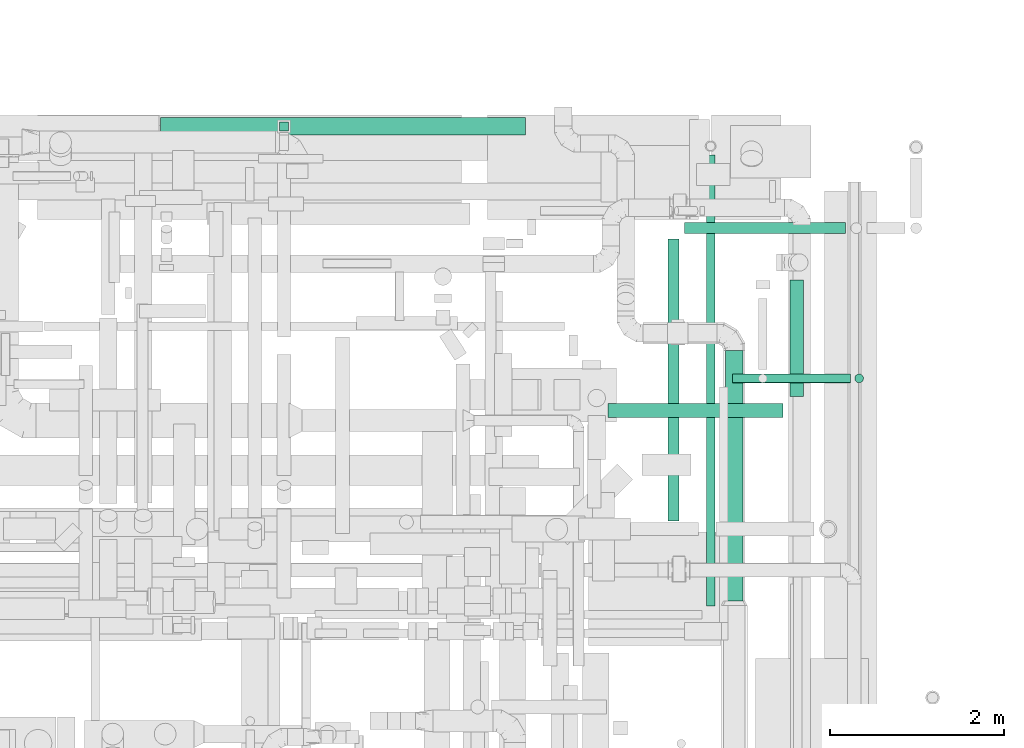
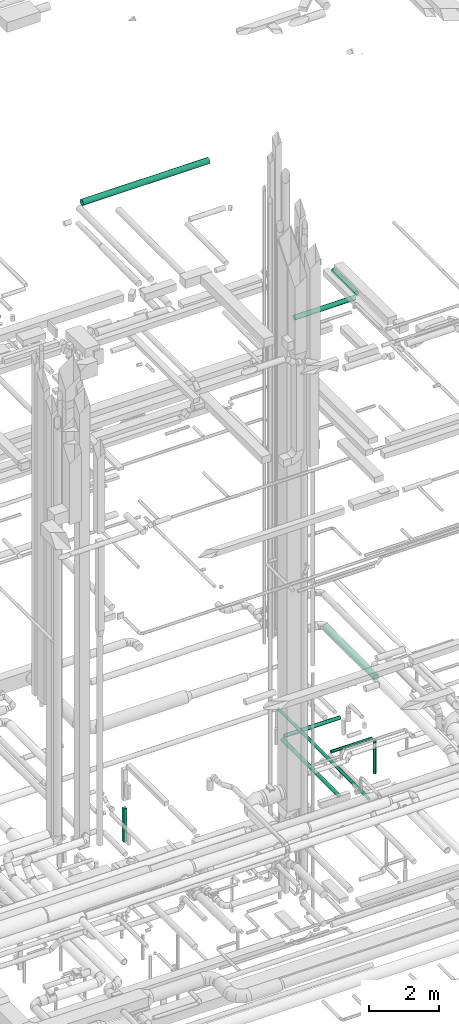
# One storey, part 78 of 337: 10 flow segments.
"""IFC2X3 building model written with IfcOpenShell, lengths in millimetres."""

import ifcopenshell
import ifcopenshell.guid

model = None  # the IFC model being written
_history = None  # IfcOwnerHistory: only IFC2X3 demands one
_inside = {}  # id of a spatial element -> (the spatial element, [elements in it])
_under = {}  # id of a project, library or spatial element -> (it, [spatial elements below it])
_declared = {}  # id of a project -> (the project, [libraries it declares])
_typed = {}  # id of a type object -> (the type object, [elements of that type])
_made_of = {}  # id of a material, layer set ... -> (it, [elements and type objects made of it])


def new_model(schema):
    """Start an empty IFC model of exactly this schema.

    Asked for "IFC4X3", IfcOpenShell would pick the latest addendum, in which some entities
    have other attributes; the version numbers below select the first issue.
    IFC2X3 requires an IfcOwnerHistory on every rooted entity: one is made here for all.
    """
    global model, _history
    if schema == "IFC4X3":
        model = ifcopenshell.file(schema_version=(4, 3, 0, 0))
    else:
        model = ifcopenshell.file(schema=schema)
    _inside.clear()
    _under.clear()
    _declared.clear()
    _typed.clear()
    _made_of.clear()
    _history = None
    if model.schema == "IFC2X3":
        org = make("IfcOrganization", Name="unknown")
        user = make(
            "IfcPersonAndOrganization",
            ThePerson=make("IfcPerson", FamilyName="unknown"),
            TheOrganization=org,
        )
        app = make(
            "IfcApplication",
            ApplicationDeveloper=org,
            Version="unknown",
            ApplicationFullName="unknown",
            ApplicationIdentifier="unknown",
        )
        _history = make(
            "IfcOwnerHistory",
            OwningUser=user,
            OwningApplication=app,
            ChangeAction="ADDED",
            CreationDate=0,
        )
    return model


def make(cls, **values):
    """One entity of the class cls with the attributes given. An attribute that is None is left unset."""
    return model.create_entity(
        cls, **{name: value for name, value in values.items() if value is not None}
    )


def entity(cls, *values):
    """Any entity or typed value of the class cls, its attributes in the order of the schema. None: left unset."""
    e = model.create_entity(cls)
    for i, value in enumerate(values):
        if value is not None:
            e[i] = value
    return e


def rooted(cls, **values):
    """An entity with a GlobalId (a new one), such as an element, a storey or a relation."""
    return make(cls, GlobalId=ifcopenshell.guid.new(), OwnerHistory=_history, **values)


def si_unit(unit_type, name, prefix=None):
    """IfcSIUnit, for example si_unit("LENGTHUNIT", "METRE", prefix="MILLI")."""
    return make("IfcSIUnit", UnitType=unit_type, Prefix=prefix, Name=name)


def converted_unit(unit_type, name, factor, base, dimensions=None, offset=None):
    """IfcConversionBasedUnit, such as the inch: factor (a typed value) times the base unit."""
    return make(
        "IfcConversionBasedUnit"
        if offset is None
        else "IfcConversionBasedUnitWithOffset",
        ConversionOffset=offset,
        Dimensions=None
        if dimensions is None
        else entity("IfcDimensionalExponents", *dimensions),
        UnitType=unit_type,
        Name=name,
        ConversionFactor=make(
            "IfcMeasureWithUnit", ValueComponent=factor, UnitComponent=base
        ),
    )


def derived_unit(unit_type, elements):
    """IfcDerivedUnit: a product of units, each with its exponent."""
    return make(
        "IfcDerivedUnit",
        Elements=[
            make("IfcDerivedUnitElement", Unit=unit, Exponent=power)
            for unit, power in elements
        ],
        UnitType=unit_type,
    )


def assignment(units):
    """IfcUnitAssignment: the units of a project."""
    return None if units is None else make("IfcUnitAssignment", Units=units)


def point(xyz):
    """IfcCartesianPoint."""
    return None if xyz is None else make("IfcCartesianPoint", Coordinates=xyz)


def direction(xyz):
    """IfcDirection."""
    return None if xyz is None else make("IfcDirection", DirectionRatios=xyz)


def frame(location, z_axis=None, x_axis=None):
    """IfcAxis2Placement3D, a coordinate frame: its origin and axes. An axis left out is left unset."""
    return make(
        "IfcAxis2Placement3D",
        Location=point(location),
        Axis=direction(z_axis),
        RefDirection=direction(x_axis),
    )


def frame_2d(location, x_axis=None):
    """IfcAxis2Placement2D, a coordinate frame in the plane: its origin and x axis."""
    return make(
        "IfcAxis2Placement2D", Location=point(location), RefDirection=direction(x_axis)
    )


def origin():
    """The frame at (0, 0, 0) with its axes left unset."""
    return frame((0.0, 0.0, 0.0))


def origin_2d_with_axis():
    """The frame at (0, 0) in the plane with the x axis (1, 0) written out."""
    return frame_2d((0.0, 0.0), x_axis=(1.0, 0.0))


def place(relative_to, where):
    """IfcLocalPlacement: puts the frame where relative to a parent placement (None: the world)."""
    return make(
        "IfcLocalPlacement", PlacementRelTo=relative_to, RelativePlacement=where
    )


def context(
    kind, dimensions, precision=None, world=None, true_north=None, identifier=None
):
    """IfcGeometricRepresentationContext, for example the 3D "Model" context."""
    return make(
        "IfcGeometricRepresentationContext",
        ContextIdentifier=identifier,
        ContextType=kind,
        CoordinateSpaceDimension=dimensions,
        Precision=precision,
        WorldCoordinateSystem=world,
        TrueNorth=true_north,
    )


def subcontext(parent, identifier, kind, view, scale=None):
    """IfcGeometricRepresentationSubContext, for example "Body" below "Model"."""
    return make(
        "IfcGeometricRepresentationSubContext",
        ContextIdentifier=identifier,
        ContextType=kind,
        ParentContext=parent,
        TargetScale=scale,
        TargetView=view,
    )


def project(units=None, contexts=None):
    """IfcProject with its units and contexts."""
    return rooted(
        "IfcProject",
        Name="project",
        RepresentationContexts=contexts,
        UnitsInContext=assignment(units),
    )


def spatial(cls, under=None, at=None, **own):
    """A site, building, storey or space (cls), placed at a placement, below another one or the project."""
    s = rooted(cls, ObjectPlacement=at, **own)
    if under is not None:
        _under.setdefault(under.id(), (under, []))[1].append(s)
    return s


def profile(cls, at=None, kind="AREA", **sizes):
    """A parametric profile (cls). Its sizes go by their IFC names, for example OverallWidth=200.0."""
    return make(cls, ProfileType=kind, Position=at, **sizes)


def rectangle(**sizes):
    """IfcRectangleProfileDef."""
    return profile("IfcRectangleProfileDef", **sizes)


def circle(**sizes):
    """IfcCircleProfileDef."""
    return profile("IfcCircleProfileDef", **sizes)


def extrude(swept, where, along, depth):
    """IfcExtrudedAreaSolid: the profile swept, set in the frame where, extruded along a direction by depth."""
    return make(
        "IfcExtrudedAreaSolid",
        SweptArea=swept,
        Position=where,
        ExtrudedDirection=direction(along),
        Depth=depth,
    )


def shape(context_of_items, identifier, shape_type, items):
    """IfcShapeRepresentation: the items that make up one representation, for example the "Body"."""
    return make(
        "IfcShapeRepresentation",
        ContextOfItems=context_of_items,
        RepresentationIdentifier=identifier,
        RepresentationType=shape_type,
        Items=items,
    )


def made_of(thing, what):
    """Note that an element or type object is made of a material, layer set ...; save() writes the relation."""
    if what is not None:
        _made_of.setdefault(what.id(), (what, []))[1].append(thing)
    return thing


def type_object(cls, material=None, **own):
    """A type object (cls), such as IfcWallType, which elements share."""
    return made_of(rooted(cls, **own), material)


def element(
    cls,
    number,
    at=None,
    inside=None,
    cuts=None,
    type_object=None,
    material=None,
    context=None,
    identifier="Body",
    shape_type=None,
    held_by="IfcProductDefinitionShape",
    body=None,
    shapes=None,
    **own,
):
    """One element of the class cls, such as IfcWall. Its Tag is "e" and its number.

    at: its placement. inside: the storey or other place that contains it. cuts: it is an
    opening in that element (IfcRelVoidsElement). A single representation is given by context,
    identifier, shape_type and body (its items); several are given by shapes. held_by: the class
    of the entity that holds the representations. save() writes the other relations.
    """
    e = rooted(cls, Tag="e%d" % number, ObjectPlacement=at, **own)
    if body is not None:
        shapes = [shape(context, identifier, shape_type, body)]
    if shapes is not None:
        e.Representation = make(held_by, Representations=shapes)
    if inside is not None:
        _inside.setdefault(inside.id(), (inside, []))[1].append(e)
    if cuts is not None:
        rooted(
            "IfcRelVoidsElement", RelatingBuildingElement=cuts, RelatedOpeningElement=e
        )
    if type_object is not None:
        _typed.setdefault(type_object.id(), (type_object, []))[1].append(e)
    return made_of(e, material)


def aggregate(whole, parts):
    """IfcRelAggregates: a whole, such as a stair, and the parts it consists of."""
    return rooted("IfcRelAggregates", RelatingObject=whole, RelatedObjects=parts)


def save(model, path):
    """Write the relations noted so far, then the file.

    IfcRelAggregates (storeys below a building ...), IfcRelContainedInSpatialStructure (elements
    in a storey), IfcRelDefinesByType, IfcRelAssociatesMaterial and IfcRelDeclares: one each for
    every whole, place, type object, material and project.
    """
    for whole, parts in _under.values():
        aggregate(whole, parts)
    for where, things in _inside.values():
        rooted(
            "IfcRelContainedInSpatialStructure",
            RelatedElements=things,
            RelatingStructure=where,
        )
    for kind, things in _typed.values():
        rooted("IfcRelDefinesByType", RelatedObjects=things, RelatingType=kind)
    for what, things in _made_of.values():
        rooted("IfcRelAssociatesMaterial", RelatedObjects=things, RelatingMaterial=what)
    for by, libraries in _declared.values():
        rooted("IfcRelDeclares", RelatingContext=by, RelatedDefinitions=libraries)
    model.write(path)


model = new_model("IFC2X3")

# Units and contexts
model_context = context("Model", 3, precision=0.01, world=origin(), true_north=direction((6.12303176911189e-17, 1.0)))
body_context = subcontext(model_context, "Body", "Model", "MODEL_VIEW")
ifc_project = project(units=[si_unit("LENGTHUNIT", "METRE", prefix="MILLI"), si_unit("AREAUNIT", "SQUARE_METRE"), si_unit("VOLUMEUNIT", "CUBIC_METRE"), converted_unit("PLANEANGLEUNIT", "DEGREE", entity("IfcRatioMeasure", 0.0174532925199433), si_unit("PLANEANGLEUNIT", "RADIAN"), dimensions=[0, 0, 0, 0, 0, 0, 0]), si_unit("MASSUNIT", "GRAM", prefix="KILO"), derived_unit("MASSDENSITYUNIT", [(si_unit("MASSUNIT", "GRAM", prefix="KILO"), 1), (si_unit("LENGTHUNIT", "METRE"), -3)]), derived_unit("MOMENTOFINERTIAUNIT", [(si_unit("LENGTHUNIT", "METRE"), 4)]), si_unit("TIMEUNIT", "SECOND"), si_unit("FREQUENCYUNIT", "HERTZ"), si_unit("THERMODYNAMICTEMPERATUREUNIT", "DEGREE_CELSIUS"), derived_unit("THERMALTRANSMITTANCEUNIT", [(si_unit("MASSUNIT", "GRAM", prefix="KILO"), 1), (si_unit("THERMODYNAMICTEMPERATUREUNIT", "KELVIN"), -1), (si_unit("TIMEUNIT", "SECOND"), -3)]), derived_unit("VOLUMETRICFLOWRATEUNIT", [(si_unit("LENGTHUNIT", "METRE"), 3), (si_unit("TIMEUNIT", "SECOND"), -1)]), derived_unit("MASSFLOWRATEUNIT", [(si_unit("MASSUNIT", "GRAM", prefix="KILO"), 1), (si_unit("TIMEUNIT", "SECOND"), -1)]), derived_unit("ROTATIONALFREQUENCYUNIT", [(si_unit("TIMEUNIT", "SECOND"), -1)]), si_unit("ELECTRICCURRENTUNIT", "AMPERE"), si_unit("ELECTRICVOLTAGEUNIT", "VOLT"), si_unit("POWERUNIT", "WATT"), si_unit("FORCEUNIT", "NEWTON", prefix="KILO"), si_unit("ILLUMINANCEUNIT", "LUX"), si_unit("LUMINOUSFLUXUNIT", "LUMEN"), si_unit("LUMINOUSINTENSITYUNIT", "CANDELA"), derived_unit("USERDEFINED", [(si_unit("MASSUNIT", "GRAM", prefix="KILO"), -1), (si_unit("LENGTHUNIT", "METRE"), -2), (si_unit("TIMEUNIT", "SECOND"), 3), (si_unit("LUMINOUSFLUXUNIT", "LUMEN"), 1)]), derived_unit("LINEARVELOCITYUNIT", [(si_unit("LENGTHUNIT", "METRE"), 1), (si_unit("TIMEUNIT", "SECOND"), -1)]), si_unit("PRESSUREUNIT", "PASCAL"), derived_unit("USERDEFINED", [(si_unit("LENGTHUNIT", "METRE"), -2), (si_unit("MASSUNIT", "GRAM", prefix="KILO"), 1), (si_unit("TIMEUNIT", "SECOND"), -2)]), derived_unit("LINEARFORCEUNIT", [(si_unit("MASSUNIT", "GRAM", prefix="KILO"), 1), (si_unit("LENGTHUNIT", "METRE"), 1), (si_unit("TIMEUNIT", "SECOND"), -2), (si_unit("LENGTHUNIT", "METRE"), -1)]), derived_unit("PLANARFORCEUNIT", [(si_unit("MASSUNIT", "GRAM", prefix="KILO"), 1), (si_unit("LENGTHUNIT", "METRE"), 1), (si_unit("TIMEUNIT", "SECOND"), -2), (si_unit("LENGTHUNIT", "METRE"), -2)])], contexts=[model_context])

# Site, building, storey
site_placement = place(None, origin())
site = spatial("IfcSite", under=ifc_project, at=site_placement, CompositionType="ELEMENT")
building_placement = place(site_placement, origin())
building = spatial("IfcBuilding", under=site, at=building_placement, CompositionType="ELEMENT")
storey_placement = place(building_placement, origin())
storey = spatial("IfcBuildingStorey", under=building, at=storey_placement, CompositionType="ELEMENT", Elevation=0.0)

# Flow segments
duct_segment_type_1 = type_object("IfcDuctSegmentType", PredefinedType="NOTDEFINED")
flow_segment_1_placement = place(storey_placement, frame((58414.14, 19923.87, -3635.0)))
element("IfcFlowSegment", 1, at=flow_segment_1_placement, inside=storey, type_object=duct_segment_type_1, context=body_context, shape_type="SweptSolid", body=[
    extrude(rectangle(XDim=99.9999999999946, YDim=99.9999999999989, at=origin_2d_with_axis()), frame((50.0, 50.0, 0.0)), (0.0, 0.0, 1.0), 1179.99999999995),
])
duct_segment_type_2 = type_object("IfcDuctSegmentType", PredefinedType="NOTDEFINED")
flow_segment_2_placement = place(storey_placement, frame((62875.41, 15443.96, -914.1)))
element("IfcFlowSegment", 2, at=flow_segment_2_placement, inside=storey, type_object=duct_segment_type_2, context=body_context, shape_type="SweptSolid", body=[
    extrude(circle(Radius=62.5, at=origin_2d_with_axis()), frame((64.1, 0.0, 64.1), z_axis=(0.0, 1.0, 0.0), x_axis=(-1.0, 0.0, 0.0)), (0.0, 0.0, 1.0), 3237.49999999837),
])
flow_segment_3_placement = place(storey_placement, frame((63064.51, 18742.36, -914.1)))
element("IfcFlowSegment", 3, at=flow_segment_3_placement, inside=storey, type_object=duct_segment_type_2, context=body_context, shape_type="SweptSolid", body=[
    extrude(circle(Radius=62.5, at=origin_2d_with_axis()), frame((0.0, 64.1, 64.1), z_axis=(1.0, 0.0, 0.0), x_axis=(0.0, -1.0, 0.0)), (0.0, 0.0, 1.0), 1848.66407999998),
])
flow_segment_4_placement = place(storey_placement, frame((63312.58, 14463.63, -571.6)))
element("IfcFlowSegment", 4, at=flow_segment_4_placement, inside=storey, type_object=duct_segment_type_2, context=body_context, shape_type="SweptSolid", body=[
    extrude(circle(Radius=50.0, at=origin_2d_with_axis()), frame((51.6, 0.0, 51.6), z_axis=(0.0, 1.0, 0.0), x_axis=(1.0, 0.0, 0.0)), (0.0, 0.0, 1.0), 5184.95332879355),
])
flow_segment_5_placement = place(storey_placement, frame((63614.2, 17028.51, -601.6)))
element("IfcFlowSegment", 5, at=flow_segment_5_placement, inside=storey, type_object=duct_segment_type_2, context=body_context, shape_type="SweptSolid", body=[
    extrude(circle(Radius=50.0, at=origin_2d_with_axis()), frame((0.0, 51.6, 51.6), z_axis=(1.0, 0.0, 0.0), x_axis=(0.0, -1.0, 0.0)), (0.0, 0.0, 1.0), 1355.78906999999),
])
flow_segment_6_placement = place(storey_placement, frame((65018.39, 17028.51, -1800.0)))
element("IfcFlowSegment", 6, at=flow_segment_6_placement, inside=storey, type_object=duct_segment_type_2, context=body_context, shape_type="SweptSolid", body=[
    extrude(circle(Radius=50.0, at=origin_2d_with_axis()), frame((51.6, 51.6, 0.0), z_axis=(0.0, 0.0, 1.0), x_axis=(0.0, -1.0, 0.0)), (0.0, 0.0, 1.0), 1150.00000000001),
])
flow_segment_7_placement = place(storey_placement, frame((63533.85, 14522.7, 3498.4)))
element("IfcFlowSegment", 7, at=flow_segment_7_placement, inside=storey, type_object=duct_segment_type_2, context=body_context, shape_type="SweptSolid", body=[
    extrude(circle(Radius=100.0, at=origin_2d_with_axis()), frame((101.6, 0.0, 101.6), z_axis=(0.0, 1.0, 0.0), x_axis=(-1.0, 0.0, 0.0)), (0.0, 0.0, 1.0), 2876.69047558311),
])
flow_segment_8_placement = place(storey_placement, frame((57045.04, 19873.92, 19098.4)))
element("IfcFlowSegment", 8, at=flow_segment_8_placement, inside=storey, type_object=duct_segment_type_2, context=body_context, shape_type="SweptSolid", body=[
    extrude(circle(Radius=100.0, at=origin_2d_with_axis()), frame((0.0, 101.6, 101.6), z_axis=(1.0, 0.0, 0.0), x_axis=(0.0, -1.0, 0.0)), (0.0, 0.0, 1.0), 4195.00000000005),
])
flow_segment_9_placement = place(storey_placement, frame((62187.93, 16631.96, 15268.4)))
element("IfcFlowSegment", 9, at=flow_segment_9_placement, inside=storey, type_object=duct_segment_type_2, context=body_context, shape_type="SweptSolid", body=[
    extrude(circle(Radius=80.0, at=origin_2d_with_axis()), frame((0.0, 81.6, 81.6), z_axis=(1.0, 0.0, 0.0), x_axis=(0.0, -1.0, 0.0)), (0.0, 0.0, 1.0), 2005.64416000001),
])
flow_segment_10_placement = place(storey_placement, frame((64271.98, 16873.56, 15268.4)))
element("IfcFlowSegment", 10, at=flow_segment_10_placement, inside=storey, type_object=duct_segment_type_2, context=body_context, shape_type="SweptSolid", body=[
    extrude(circle(Radius=80.0, at=origin_2d_with_axis()), frame((81.6, 0.0, 81.6), z_axis=(0.0, 1.0, 0.0), x_axis=(1.0, 0.0, 0.0)), (0.0, 0.0, 1.0), 1340.00000000001),
])

save(model, "model.ifc")
